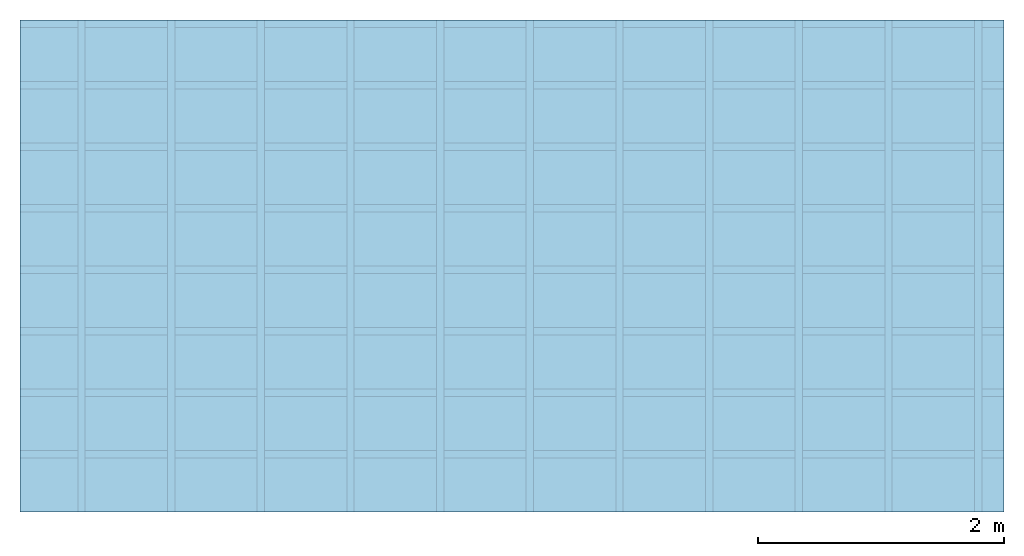
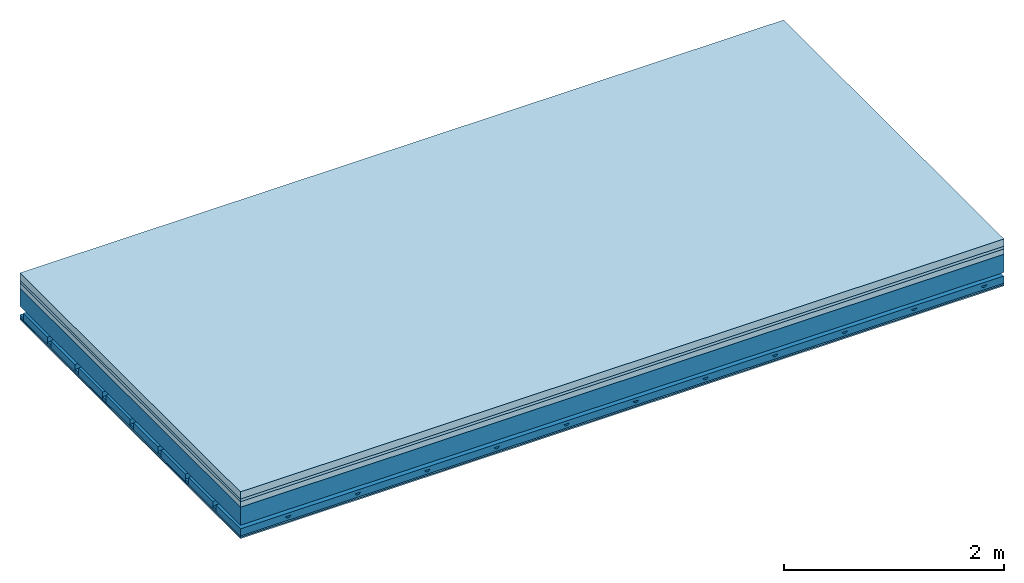
# One storey: 5 plates, 4 members, 1 element without a shape of its own.
"""IFC4 building model written with IfcOpenShell, lengths in metres."""

from ifc_helpers import new_model, si_unit, derived_unit, direction, frame, frame_2d, origin, origin_with_axes, place, context, project, spatial, polyline, rectangle, outline, extrude, material, layer, layer_set, type_object, element, aggregate, save


model = new_model("IFC4")

# Units and contexts
plan_context = context("Plan", 3, precision=1e-05, world=origin(), true_north=direction((0.0, 1.0)))
model_context = context("Model", 3, precision=1e-05, world=origin(), true_north=direction((0.0, 1.0)))
ifc_project = project(units=[si_unit("LENGTHUNIT", "METRE"), derived_unit("SOUNDPRESSUREUNIT", [(si_unit("PRESSUREUNIT", "PASCAL", prefix="MICRO"), 0)]), si_unit("ENERGYUNIT", "JOULE", prefix="MEGA"), si_unit("MASSUNIT", "GRAM", prefix="KILO"), derived_unit("THERMALTRANSMITTANCEUNIT", [(si_unit("POWERUNIT", "WATT"), 1), (si_unit("AREAUNIT", "SQUARE_METRE"), -1), (si_unit("THERMODYNAMICTEMPERATUREUNIT", "KELVIN"), -1)]), derived_unit("AREADENSITYUNIT", [(si_unit("MASSUNIT", "GRAM", prefix="KILO"), 1), (si_unit("AREAUNIT", "SQUARE_METRE"), -1)]), derived_unit("USERDEFINED", [(si_unit("ENERGYUNIT", "JOULE", prefix="MEGA"), 1), (si_unit("AREAUNIT", "SQUARE_METRE"), -1)])], contexts=[plan_context, model_context])

# Site, building, storey
site = spatial("IfcSite", under=ifc_project)
building_placement = place(None, origin())
building = spatial("IfcBuilding", under=site, at=building_placement)
storey_placement = place(building_placement, origin())
storey = spatial("IfcBuildingStorey", under=building, at=storey_placement)

# Slab, members, plates
ifc_material_1 = material(Name="Cement screed", Category="04.006")
ifc_layer_1 = layer(ifc_material_1, 0.08, Name="On-material")
ifc_material_2 = material()
ifc_layer_2 = layer(ifc_material_2, 0.03, Name="Impact sound insulation")
ifc_material_3 = material(Category="03.011")
ifc_layer_3 = layer(ifc_material_3, 0.06, Name="on Supporting structure")
ifc_layer_4 = layer(None, 0.2, Name="Supporting structure")
ifc_material_4 = material(Name="no composite action")
ifc_layer_5 = layer(ifc_material_4, 0.0, Name="Bond")
ifc_layer_6 = layer(None, 0.093, Name="Coupling")
ifc_layer_7 = layer(None, 0.027, Name="Battens / profiles")
ifc_material_5 = material(Category="03.007")
ifc_layer_8 = layer(ifc_material_5, 0.015, Name="Ceiling covering 1st layer")
ifc_layer_9 = layer(ifc_material_5, 0.015, Name="Ceiling covering layer 2")
ifc_material_6 = material(Name="Glued joints")
ifc_layer_10 = layer(ifc_material_6, 0.0, Name="Surface / treatment")
ifc_layer_set = layer_set([ifc_layer_1, ifc_layer_2, ifc_layer_3, ifc_layer_4, ifc_layer_5, ifc_layer_6, ifc_layer_7, ifc_layer_8, ifc_layer_9, ifc_layer_10])
slab_type = type_object("IfcSlabType", Name="A1158", PredefinedType="NOTDEFINED", material=ifc_layer_set)
slab_placement = place(None, frame((0.0, 0.0, 0.0), z_axis=(0.0, 0.0, -1.0), x_axis=(1.0, 0.0, 0.0)))
slab = element("IfcSlab", 1, at=slab_placement, inside=storey, type_object=slab_type, material=ifc_layer_set, Name="Slab #1")
ifc_material_7 = material()
member_1_placement = place(slab_placement, origin())
member_1 = element("IfcMember", 2, at=member_1_placement, material=ifc_material_7, Name="Supporting structure", context=plan_context, shape_type="SweptSolid", body=[
    extrude(rectangle(XDim=1.0, YDim=0.2, at=frame_2d((0.5, 0.1), x_axis=(1.0, 0.0))), frame((0.0, 4.0, 0.17), z_axis=(0.0, -1.0, 0.0), x_axis=(1.0, 0.0, 0.0)), (0.0, 0.0, 1.0), 4.0),
    extrude(rectangle(XDim=1.0, YDim=0.2, at=frame_2d((0.5, 0.1), x_axis=(1.0, 0.0))), frame((1.0, 4.0, 0.17), z_axis=(0.0, -1.0, 0.0), x_axis=(1.0, 0.0, 0.0)), (0.0, 0.0, 1.0), 4.0),
    extrude(rectangle(XDim=1.0, YDim=0.2, at=frame_2d((0.5, 0.1), x_axis=(1.0, 0.0))), frame((2.0, 4.0, 0.17), z_axis=(0.0, -1.0, 0.0), x_axis=(1.0, 0.0, 0.0)), (0.0, 0.0, 1.0), 4.0),
    extrude(rectangle(XDim=1.0, YDim=0.2, at=frame_2d((0.5, 0.1), x_axis=(1.0, 0.0))), frame((3.0, 4.0, 0.17), z_axis=(0.0, -1.0, 0.0), x_axis=(1.0, 0.0, 0.0)), (0.0, 0.0, 1.0), 4.0),
    extrude(rectangle(XDim=1.0, YDim=0.2, at=frame_2d((0.5, 0.1), x_axis=(1.0, 0.0))), frame((4.0, 4.0, 0.17), z_axis=(0.0, -1.0, 0.0), x_axis=(1.0, 0.0, 0.0)), (0.0, 0.0, 1.0), 4.0),
    extrude(rectangle(XDim=1.0, YDim=0.2, at=frame_2d((0.5, 0.1), x_axis=(1.0, 0.0))), frame((5.0, 4.0, 0.17), z_axis=(0.0, -1.0, 0.0), x_axis=(1.0, 0.0, 0.0)), (0.0, 0.0, 1.0), 4.0),
    extrude(rectangle(XDim=1.0, YDim=0.2, at=frame_2d((0.5, 0.1), x_axis=(1.0, 0.0))), frame((6.0, 4.0, 0.17), z_axis=(0.0, -1.0, 0.0), x_axis=(1.0, 0.0, 0.0)), (0.0, 0.0, 1.0), 4.0),
    extrude(rectangle(XDim=1.0, YDim=0.2, at=frame_2d((0.5, 0.1), x_axis=(1.0, 0.0))), frame((7.0, 4.0, 0.17), z_axis=(0.0, -1.0, 0.0), x_axis=(1.0, 0.0, 0.0)), (0.0, 0.0, 1.0), 4.0),
])
ifc_material_8 = material()
member_2_placement = place(slab_placement, origin())
member_2 = element("IfcMember", 3, at=member_2_placement, material=ifc_material_8, Name="Coupling", context=plan_context, shape_type="SweptSolid", body=[
    extrude(outline(polyline([(0.0, 0.0), (0.06, 0.0), (0.04, 0.02), (0.02, 0.02), (0.0, 0.0)])), frame((0.47, 4.0, 0.443), z_axis=(0.0, -1.0, 0.0), x_axis=(1.0, 0.0, 0.0)), (0.0, 0.0, 1.0), 4.0),
    extrude(outline(polyline([(0.0, 0.0), (0.06, 0.0), (0.04, 0.02), (0.02, 0.02), (0.0, 0.0)])), frame((1.199, 4.0, 0.443), z_axis=(0.0, -1.0, 0.0), x_axis=(1.0, 0.0, 0.0)), (0.0, 0.0, 1.0), 4.0),
    extrude(outline(polyline([(0.0, 0.0), (0.06, 0.0), (0.04, 0.02), (0.02, 0.02), (0.0, 0.0)])), frame((1.928, 4.0, 0.443), z_axis=(0.0, -1.0, 0.0), x_axis=(1.0, 0.0, 0.0)), (0.0, 0.0, 1.0), 4.0),
    extrude(outline(polyline([(0.0, 0.0), (0.06, 0.0), (0.04, 0.02), (0.02, 0.02), (0.0, 0.0)])), frame((2.657, 4.0, 0.443), z_axis=(0.0, -1.0, 0.0), x_axis=(1.0, 0.0, 0.0)), (0.0, 0.0, 1.0), 4.0),
    extrude(outline(polyline([(0.0, 0.0), (0.06, 0.0), (0.04, 0.02), (0.02, 0.02), (0.0, 0.0)])), frame((3.386, 4.0, 0.443), z_axis=(0.0, -1.0, 0.0), x_axis=(1.0, 0.0, 0.0)), (0.0, 0.0, 1.0), 4.0),
    extrude(outline(polyline([(0.0, 0.0), (0.06, 0.0), (0.04, 0.02), (0.02, 0.02), (0.0, 0.0)])), frame((4.115, 4.0, 0.443), z_axis=(0.0, -1.0, 0.0), x_axis=(1.0, 0.0, 0.0)), (0.0, 0.0, 1.0), 4.0),
    extrude(outline(polyline([(0.0, 0.0), (0.06, 0.0), (0.04, 0.02), (0.02, 0.02), (0.0, 0.0)])), frame((4.844, 4.0, 0.443), z_axis=(0.0, -1.0, 0.0), x_axis=(1.0, 0.0, 0.0)), (0.0, 0.0, 1.0), 4.0),
    extrude(outline(polyline([(0.0, 0.0), (0.06, 0.0), (0.04, 0.02), (0.02, 0.02), (0.0, 0.0)])), frame((5.573, 4.0, 0.443), z_axis=(0.0, -1.0, 0.0), x_axis=(1.0, 0.0, 0.0)), (0.0, 0.0, 1.0), 4.0),
    extrude(outline(polyline([(0.0, 0.0), (0.06, 0.0), (0.04, 0.02), (0.02, 0.02), (0.0, 0.0)])), frame((6.302, 4.0, 0.443), z_axis=(0.0, -1.0, 0.0), x_axis=(1.0, 0.0, 0.0)), (0.0, 0.0, 1.0), 4.0),
    extrude(outline(polyline([(0.0, 0.0), (0.06, 0.0), (0.04, 0.02), (0.02, 0.02), (0.0, 0.0)])), frame((7.031, 4.0, 0.443), z_axis=(0.0, -1.0, 0.0), x_axis=(1.0, 0.0, 0.0)), (0.0, 0.0, 1.0), 4.0),
    extrude(outline(polyline([(0.0, 0.0), (0.06, 0.0), (0.04, 0.02), (0.02, 0.02), (0.0, 0.0)])), frame((7.76, 4.0, 0.443), z_axis=(0.0, -1.0, 0.0), x_axis=(1.0, 0.0, 0.0)), (0.0, 0.0, 1.0), 4.0),
])
ifc_material_9 = material()
member_3_placement = place(slab_placement, origin())
member_3 = element("IfcMember", 4, at=member_3_placement, material=ifc_material_9, Name="Battens / profiles", context=plan_context, shape_type="SweptSolid", body=[
    extrude(rectangle(XDim=0.06, YDim=0.027, at=frame_2d((0.03, 0.0135), x_axis=(1.0, 0.0))), frame((0.0, 0.0, 0.463), z_axis=(1.0, 0.0, 0.0), x_axis=(0.0, 1.0, 0.0)), (0.0, 0.0, 1.0), 8.0),
    extrude(rectangle(XDim=0.06, YDim=0.027, at=frame_2d((0.03, 0.0135), x_axis=(1.0, 0.0))), frame((0.0, 0.5, 0.463), z_axis=(1.0, 0.0, 0.0), x_axis=(0.0, 1.0, 0.0)), (0.0, 0.0, 1.0), 8.0),
    extrude(rectangle(XDim=0.06, YDim=0.027, at=frame_2d((0.03, 0.0135), x_axis=(1.0, 0.0))), frame((0.0, 1.0, 0.463), z_axis=(1.0, 0.0, 0.0), x_axis=(0.0, 1.0, 0.0)), (0.0, 0.0, 1.0), 8.0),
    extrude(rectangle(XDim=0.06, YDim=0.027, at=frame_2d((0.03, 0.0135), x_axis=(1.0, 0.0))), frame((0.0, 1.5, 0.463), z_axis=(1.0, 0.0, 0.0), x_axis=(0.0, 1.0, 0.0)), (0.0, 0.0, 1.0), 8.0),
    extrude(rectangle(XDim=0.06, YDim=0.027, at=frame_2d((0.03, 0.0135), x_axis=(1.0, 0.0))), frame((0.0, 2.0, 0.463), z_axis=(1.0, 0.0, 0.0), x_axis=(0.0, 1.0, 0.0)), (0.0, 0.0, 1.0), 8.0),
    extrude(rectangle(XDim=0.06, YDim=0.027, at=frame_2d((0.03, 0.0135), x_axis=(1.0, 0.0))), frame((0.0, 2.5, 0.463), z_axis=(1.0, 0.0, 0.0), x_axis=(0.0, 1.0, 0.0)), (0.0, 0.0, 1.0), 8.0),
    extrude(rectangle(XDim=0.06, YDim=0.027, at=frame_2d((0.03, 0.0135), x_axis=(1.0, 0.0))), frame((0.0, 3.0, 0.463), z_axis=(1.0, 0.0, 0.0), x_axis=(0.0, 1.0, 0.0)), (0.0, 0.0, 1.0), 8.0),
    extrude(rectangle(XDim=0.06, YDim=0.027, at=frame_2d((0.03, 0.0135), x_axis=(1.0, 0.0))), frame((0.0, 3.5, 0.463), z_axis=(1.0, 0.0, 0.0), x_axis=(0.0, 1.0, 0.0)), (0.0, 0.0, 1.0), 8.0),
])
ifc_material_10 = material()
member_4_placement = place(slab_placement, origin())
member_4 = element("IfcMember", 5, at=member_4_placement, material=ifc_material_10, Name="Cavity", context=plan_context, shape_type="SweptSolid", body=[
    extrude(rectangle(XDim=0.44, YDim=0.08, at=frame_2d((0.22, 0.04), x_axis=(1.0, 0.0))), frame((0.0, 0.06, 0.41), z_axis=(1.0, 0.0, 0.0), x_axis=(0.0, 1.0, 0.0)), (0.0, 0.0, 1.0), 8.0),
    extrude(rectangle(XDim=0.44, YDim=0.08, at=frame_2d((0.22, 0.04), x_axis=(1.0, 0.0))), frame((0.0, 0.56, 0.41), z_axis=(1.0, 0.0, 0.0), x_axis=(0.0, 1.0, 0.0)), (0.0, 0.0, 1.0), 8.0),
    extrude(rectangle(XDim=0.44, YDim=0.08, at=frame_2d((0.22, 0.04), x_axis=(1.0, 0.0))), frame((0.0, 1.06, 0.41), z_axis=(1.0, 0.0, 0.0), x_axis=(0.0, 1.0, 0.0)), (0.0, 0.0, 1.0), 8.0),
    extrude(rectangle(XDim=0.44, YDim=0.08, at=frame_2d((0.22, 0.04), x_axis=(1.0, 0.0))), frame((0.0, 1.56, 0.41), z_axis=(1.0, 0.0, 0.0), x_axis=(0.0, 1.0, 0.0)), (0.0, 0.0, 1.0), 8.0),
    extrude(rectangle(XDim=0.44, YDim=0.08, at=frame_2d((0.22, 0.04), x_axis=(1.0, 0.0))), frame((0.0, 2.06, 0.41), z_axis=(1.0, 0.0, 0.0), x_axis=(0.0, 1.0, 0.0)), (0.0, 0.0, 1.0), 8.0),
    extrude(rectangle(XDim=0.44, YDim=0.08, at=frame_2d((0.22, 0.04), x_axis=(1.0, 0.0))), frame((0.0, 2.56, 0.41), z_axis=(1.0, 0.0, 0.0), x_axis=(0.0, 1.0, 0.0)), (0.0, 0.0, 1.0), 8.0),
    extrude(rectangle(XDim=0.44, YDim=0.08, at=frame_2d((0.22, 0.04), x_axis=(1.0, 0.0))), frame((0.0, 3.06, 0.41), z_axis=(1.0, 0.0, 0.0), x_axis=(0.0, 1.0, 0.0)), (0.0, 0.0, 1.0), 8.0),
    extrude(rectangle(XDim=0.44, YDim=0.08, at=frame_2d((0.22, 0.04), x_axis=(1.0, 0.0))), frame((0.0, 3.56, 0.41), z_axis=(1.0, 0.0, 0.0), x_axis=(0.0, 1.0, 0.0)), (0.0, 0.0, 1.0), 8.0),
])
plate_1_placement = place(slab_placement, origin())
plate_1 = element("IfcPlate", 6, at=plate_1_placement, material=ifc_material_1, Name="On-material", context=plan_context, shape_type="SweptSolid", body=[
    extrude(rectangle(XDim=8.0, YDim=4.0, at=frame_2d((4.0, 2.0), x_axis=(1.0, 0.0))), origin_with_axes(), (0.0, 0.0, 1.0), 0.08),
])
plate_2_placement = place(slab_placement, origin())
plate_2 = element("IfcPlate", 7, at=plate_2_placement, material=ifc_material_2, Name="Impact sound insulation", context=plan_context, shape_type="SweptSolid", body=[
    extrude(rectangle(XDim=8.0, YDim=4.0, at=frame_2d((4.0, 2.0), x_axis=(1.0, 0.0))), frame((0.0, 0.0, 0.08), z_axis=(0.0, 0.0, 1.0), x_axis=(1.0, 0.0, 0.0)), (0.0, 0.0, 1.0), 0.03),
])
plate_3_placement = place(slab_placement, origin())
plate_3 = element("IfcPlate", 8, at=plate_3_placement, material=ifc_material_3, Name="on Supporting structure", context=plan_context, shape_type="SweptSolid", body=[
    extrude(rectangle(XDim=8.0, YDim=4.0, at=frame_2d((4.0, 2.0), x_axis=(1.0, 0.0))), frame((0.0, 0.0, 0.11), z_axis=(0.0, 0.0, 1.0), x_axis=(1.0, 0.0, 0.0)), (0.0, 0.0, 1.0), 0.06),
])
plate_4_placement = place(slab_placement, origin())
plate_4 = element("IfcPlate", 9, at=plate_4_placement, material=ifc_material_5, Name="Ceiling covering 1st layer", context=plan_context, shape_type="SweptSolid", body=[
    extrude(rectangle(XDim=8.0, YDim=4.0, at=frame_2d((4.0, 2.0), x_axis=(1.0, 0.0))), frame((0.0, 0.0, 0.49), z_axis=(0.0, 0.0, 1.0), x_axis=(1.0, 0.0, 0.0)), (0.0, 0.0, 1.0), 0.015),
])
plate_5_placement = place(slab_placement, origin())
plate_5 = element("IfcPlate", 10, at=plate_5_placement, material=ifc_material_5, Name="Ceiling covering layer 2", context=plan_context, shape_type="SweptSolid", body=[
    extrude(rectangle(XDim=8.0, YDim=4.0, at=frame_2d((4.0, 2.0), x_axis=(1.0, 0.0))), frame((0.0, 0.0, 0.505), z_axis=(0.0, 0.0, 1.0), x_axis=(1.0, 0.0, 0.0)), (0.0, 0.0, 1.0), 0.015),
])
aggregate(slab, [plate_1, plate_2, plate_3, member_1, member_2, member_3, member_4, plate_4, plate_5])

save(model, "model.ifc")
